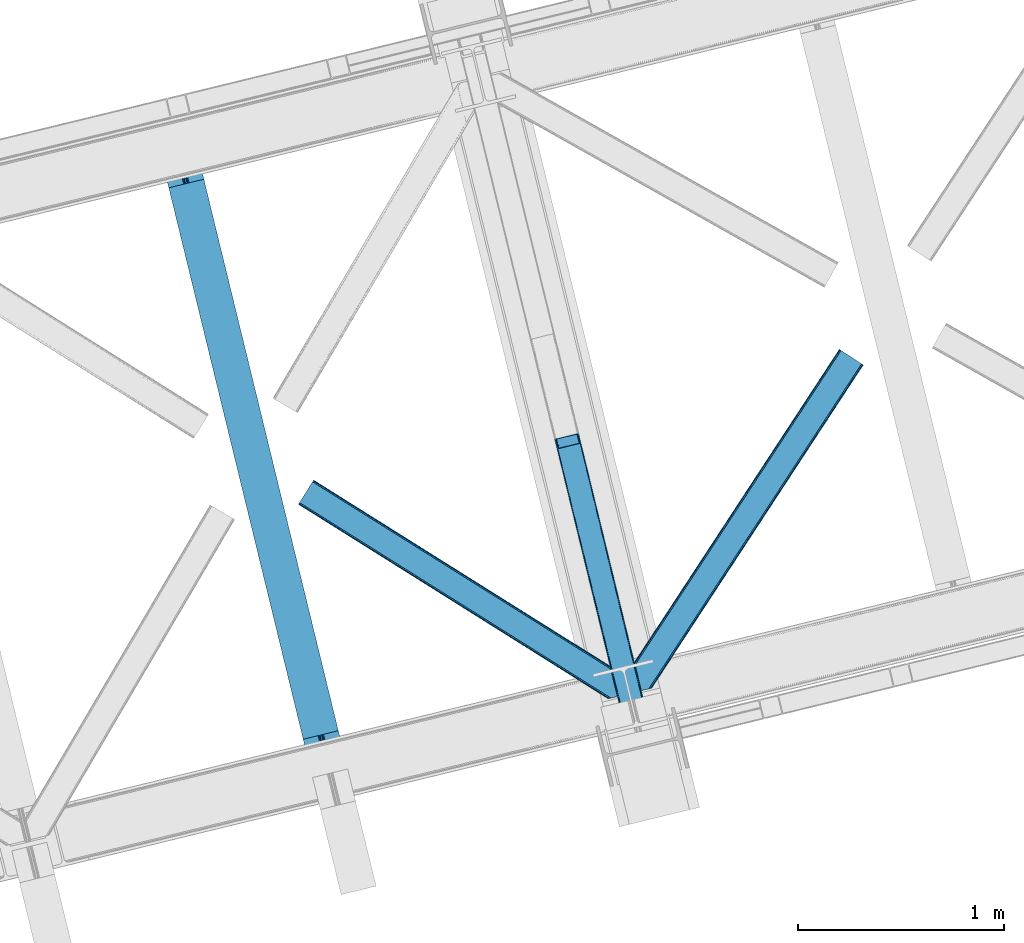
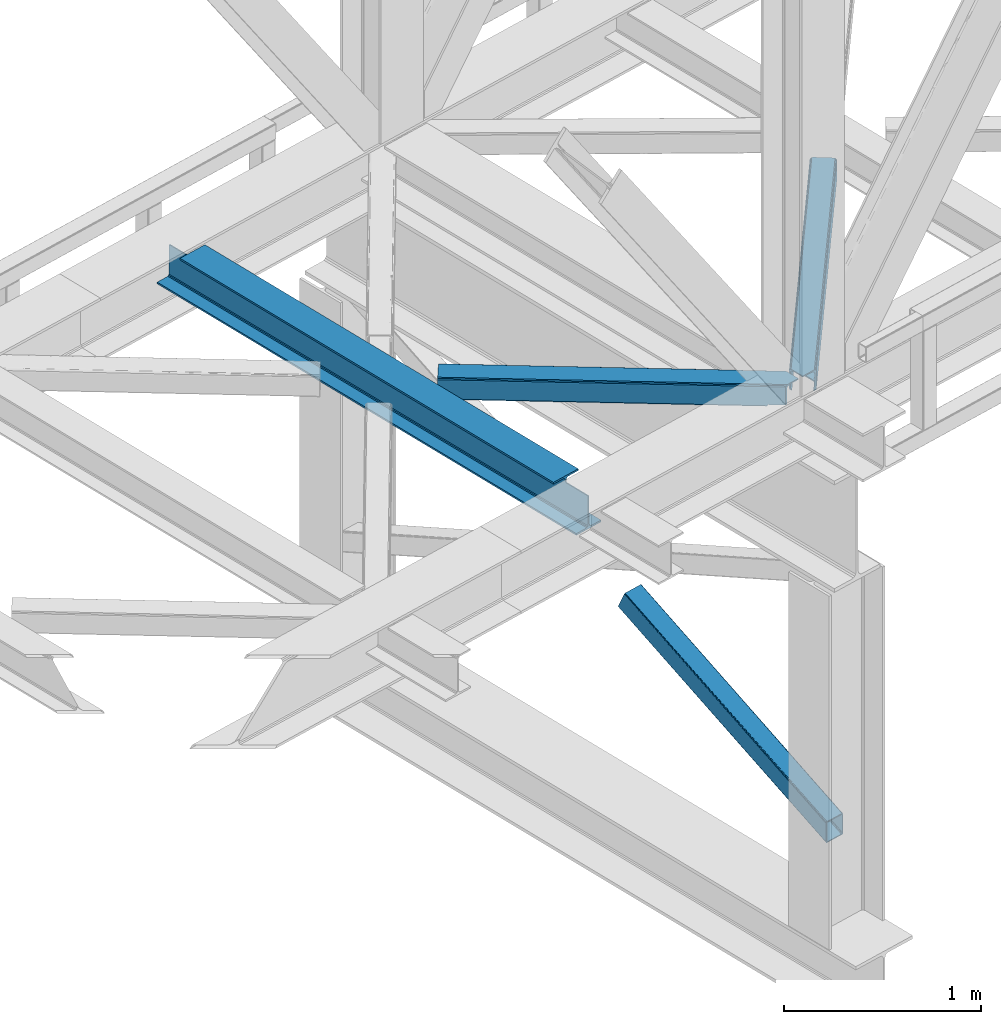
# One storey, part 36 of 93: 3 members, 1 beam.
"""IFC4 building model written with IfcOpenShell, lengths in millimetres."""

from ifc_helpers import new_model, entity, si_unit, converted_unit, derived_unit, direction, frame, origin, place, context, subcontext, project, spatial, triangles, polygons, material, type_object, element, save


model = new_model("IFC4")

# Units and contexts
model_context = context("Model", 3, precision=0.01, world=origin(), true_north=direction((6.12303176911189e-17, 1.0)))
plan_context = context("Plan", 3, precision=0.01, world=origin(), true_north=direction((6.12303176911189e-17, 1.0)))
body_context = subcontext(model_context, "Body", "Model", "MODEL_VIEW")
ifc_project = project(units=[si_unit("LENGTHUNIT", "METRE", prefix="MILLI"), si_unit("AREAUNIT", "SQUARE_METRE"), si_unit("VOLUMEUNIT", "CUBIC_METRE"), converted_unit("PLANEANGLEUNIT", "DEGREE", entity("IfcRatioMeasure", 0.0174532925199433), si_unit("PLANEANGLEUNIT", "RADIAN"), dimensions=[0, 0, 0, 0, 0, 0, 0]), si_unit("MASSUNIT", "GRAM", prefix="KILO"), derived_unit("MASSDENSITYUNIT", [(si_unit("MASSUNIT", "GRAM", prefix="KILO"), 1), (si_unit("LENGTHUNIT", "METRE"), -3)]), derived_unit("MOMENTOFINERTIAUNIT", [(si_unit("LENGTHUNIT", "METRE"), 4)]), si_unit("TIMEUNIT", "SECOND"), si_unit("FREQUENCYUNIT", "HERTZ"), si_unit("THERMODYNAMICTEMPERATUREUNIT", "DEGREE_CELSIUS"), derived_unit("THERMALTRANSMITTANCEUNIT", [(si_unit("MASSUNIT", "GRAM", prefix="KILO"), 1), (si_unit("THERMODYNAMICTEMPERATUREUNIT", "KELVIN"), -1), (si_unit("TIMEUNIT", "SECOND"), -3)]), derived_unit("VOLUMETRICFLOWRATEUNIT", [(si_unit("LENGTHUNIT", "METRE"), 3), (si_unit("TIMEUNIT", "SECOND"), -1)]), derived_unit("MASSFLOWRATEUNIT", [(si_unit("MASSUNIT", "GRAM", prefix="KILO"), 1), (si_unit("TIMEUNIT", "SECOND"), -1)]), derived_unit("ROTATIONALFREQUENCYUNIT", [(si_unit("TIMEUNIT", "SECOND"), -1)]), si_unit("ELECTRICCURRENTUNIT", "AMPERE"), si_unit("ELECTRICVOLTAGEUNIT", "VOLT"), si_unit("POWERUNIT", "WATT"), si_unit("FORCEUNIT", "NEWTON", prefix="KILO"), si_unit("ILLUMINANCEUNIT", "LUX"), si_unit("LUMINOUSFLUXUNIT", "LUMEN"), si_unit("LUMINOUSINTENSITYUNIT", "CANDELA"), derived_unit("USERDEFINED", [(si_unit("MASSUNIT", "GRAM", prefix="KILO"), -1), (si_unit("LENGTHUNIT", "METRE"), -2), (si_unit("TIMEUNIT", "SECOND"), 3), (si_unit("LUMINOUSFLUXUNIT", "LUMEN"), 1)]), derived_unit("LINEARVELOCITYUNIT", [(si_unit("LENGTHUNIT", "METRE"), 1), (si_unit("TIMEUNIT", "SECOND"), -1)]), si_unit("PRESSUREUNIT", "PASCAL"), derived_unit("USERDEFINED", [(si_unit("LENGTHUNIT", "METRE"), -2), (si_unit("MASSUNIT", "GRAM", prefix="KILO"), 1), (si_unit("TIMEUNIT", "SECOND"), -2)]), derived_unit("LINEARFORCEUNIT", [(si_unit("MASSUNIT", "GRAM", prefix="KILO"), 1), (si_unit("LENGTHUNIT", "METRE"), 1), (si_unit("TIMEUNIT", "SECOND"), -2), (si_unit("LENGTHUNIT", "METRE"), -1)]), derived_unit("PLANARFORCEUNIT", [(si_unit("MASSUNIT", "GRAM", prefix="KILO"), 1), (si_unit("LENGTHUNIT", "METRE"), 1), (si_unit("TIMEUNIT", "SECOND"), -2), (si_unit("LENGTHUNIT", "METRE"), -2)])], contexts=[model_context, plan_context])

# Site, building, storey
site_placement = place(None, origin())
site = spatial("IfcSite", under=ifc_project, at=site_placement, CompositionType="ELEMENT")
building_placement = place(site_placement, origin())
building = spatial("IfcBuilding", under=site, at=building_placement, CompositionType="ELEMENT")
storey_placement = place(building_placement, frame((0.0, 0.0, 15900.0)))
storey = spatial("IfcBuildingStorey", under=building, at=storey_placement, CompositionType="ELEMENT", Elevation=15900.0)

# Beam
ifc_material = material(Name="Metal painted (White)")
beam_type = type_object("IfcBeamType", PredefinedType="BEAM")
beam_placement = place(storey_placement, frame((-50891.9203165224, 5381.26080085439, 3441.0)))
element("IfcBeam", 1, at=beam_placement, inside=storey, type_object=beam_type, material=ifc_material, ObjectType="Steel Beam", PredefinedType="BEAM", context=body_context, shape_type="Tessellation", body=[
    polygons([(900.98534618944, 41.4445662733081, 11.000000000004), (900.98534618944, 41.4445662733081, 2.16573425859679e-12), (170.021610174761, 3040.13999372697, 2.16573425859679e-12), (170.021610174761, 3040.13999372697, 11.000000000004), (834.919806235823, 25.3403919499656, 11.000000000004), (103.956070221144, 3024.03581940362, 11.000000000004), (828.971056214531, 23.8903211957385, 12.2179274798217), (98.0073201998513, 3022.5857486494, 12.2179274798217), (823.927949458422, 22.6610105689183, 15.6862915010192), (92.9642134437427, 3021.35643802258, 15.6862915010192), (820.558253255246, 21.8396114687119, 20.8770650821657), (89.5945172405668, 3020.53503892237, 20.8770650821657), (819.374973305552, 21.5511744621195, 27.0000000000047), (88.4112372908809, 3020.24660191578, 27.0000000000047), (81.6103728838888, 3018.58881926485, 27.0000000000047), (81.6103728838888, 3018.58881926485, 203.000000000006), (88.4112372908723, 3020.24660191578, 203.000000000006), (0.0, 2998.69542745366, 2.16573425859679e-12), (0.0, 2998.69542745366, 10.9999999999997), (66.0655399536172, 3014.799601777, 11.000000000004), (72.0142899749184, 3016.24967253123, 12.2179274798217), (77.057396731027, 3017.47898315805, 15.6862915010192), (80.4270929342029, 3018.30038225826, 20.8770650821657), (819.374973305552, 21.5511744621195, 203.000000000006), (812.574108898559, 19.8933918111876, 203.000000000006), (812.574108898559, 19.8933918111876, 27.0000000000047), (811.390828948873, 19.6049548045963, 20.8770650821657), (808.021132745689, 18.7835557043887, 15.6862915010192), (802.978025989589, 17.5542450775675, 12.2179274798217), (797.029275968288, 16.1041743233425, 11.000000000004), (730.963736014679, -1.08286712929839e-12, 10.9999999999997), (730.963736014679, -1.08286712929839e-12, 2.16573425859679e-12), (779.675212882749, 184.415062601691, 203.069791966819), (128.020401343512, 2857.75452019162, 203.000000000006), (128.243282132658, 2856.8401777572, 203.617301946336), (128.256196377177, 2856.7871977843, 217.000003693143), (779.530009633833, 185.010597404071, 217.000003676718), (779.530880241722, 185.007025963191, 204.00000679514), (772.96491171832, 182.385463974441, 203.006342981529), (772.742064056782, 183.299815969774, 203.617301946336), (772.729149812254, 183.352795942668, 217.000003693143), (121.455336555608, 2855.1293963229, 217.000003676718), (121.45446594771, 2855.13296776377, 204.00000679514), (121.310166358664, 2855.72494066435, 203.076120467494), (121.219536936511, 2856.09673754069, 203.000000000006), (780.713494357877, 185.298194377514, 223.122939328039), (784.082490766539, 186.122464201393, 228.313710402595), (789.125126170563, 187.353708426698, 231.782072735464), (795.073705041275, 188.80448128138, 232.999999602236), (861.13915590679, 204.909021065314, 232.999999283132), (861.137682570352, 204.915065042187, 243.999994005812), (691.116301666431, 163.469558245297, 243.999994827032), (691.117775002877, 163.463514268424, 233.000000104353), (757.183225868392, 179.568054052358, 232.999999785253), (763.132130996731, 181.017488520583, 231.782072861012), (768.175695503853, 182.244921343717, 228.313710479427), (771.546082413602, 183.063487001147, 223.12293937232), (120.271851831563, 2854.84179934945, 223.122939328039), (116.902855422893, 2854.01752952557, 228.313710402595), (111.860220018877, 2852.78628530027, 231.782072735464), (105.911641148165, 2851.33551244559, 232.999999602236), (39.8461902826419, 2835.23097266165, 232.999999283128), (39.8476636190794, 2835.22492868478, 243.999994005812), (209.869044522992, 2876.67043548167, 243.999994827032), (209.867571186554, 2876.67647945854, 233.000000104357), (143.802120321031, 2860.57193967461, 232.999999785253), (137.85321519271, 2859.12250520638, 231.782072861012), (132.809650685579, 2857.89507238325, 228.313710479427), (129.439263775838, 2857.07650672582, 223.12293937232)], [[[1, 2, 3, 4]], [[5, 1, 4, 6]], [[7, 5, 6, 8]], [[9, 7, 8, 10]], [[11, 9, 10, 12]], [[13, 11, 12, 14]], [[15, 16, 17, 14, 12, 10, 8, 6, 4, 3, 18, 19, 20, 21, 22, 23]], [[13, 24, 25, 26, 27, 28, 29, 30, 31, 32, 2, 1, 5, 7, 9, 11]], [[2, 32, 18, 3]], [[32, 31, 19, 18]], [[31, 30, 20, 19]], [[27, 26, 15, 23]], [[28, 27, 23, 22]], [[29, 28, 22, 21]], [[30, 29, 21, 20]], [[33, 24, 13, 14, 17, 34, 35, 36, 37, 38]], [[25, 39, 40, 41, 42, 43, 44, 16, 15, 26]], [[39, 25, 24, 33]], [[45, 34, 17, 16]], [[41, 40, 38, 37, 46, 47, 48, 49, 50, 51, 52, 53, 54, 55, 56, 57]], [[42, 58, 59, 60, 61, 62, 63, 64, 65, 66, 67, 68, 69, 36, 35, 43]], [[46, 37, 36, 69]], [[47, 46, 69, 68]], [[48, 47, 68, 67]], [[49, 48, 67, 66]], [[50, 49, 66, 65]], [[51, 50, 65, 64]], [[52, 51, 64, 63]], [[53, 52, 63, 62]], [[54, 53, 62, 61]], [[55, 54, 61, 60]], [[56, 55, 60, 59]], [[57, 56, 59, 58]], [[41, 57, 58, 42]]], closed=False),
])

# Members
member_type_1 = type_object("IfcMemberType", PredefinedType="BRACE")
member_1_placement = place(storey_placement, frame((-48982.3357543945, 5508.86839599609, 911.279672241211)))
element("IfcMember", 2, at=member_1_placement, inside=storey, type_object=member_type_1, ObjectType="Steel Vertical Brace", PredefinedType="BRACE", context=body_context, shape_type="Tessellation", body=[
    triangles([(109.104968261716, 1516.67777252197, 692.224026489257), (472.287451171876, 26.761738586426, 0.0), (369.303039550781, 1.65803833007885, 0.0), (6.11590576171875, 1491.57407226563, 692.224026489257), (115.806884765625, 1516.48185424805, 696.163320922849), (116.583581542967, 1515.53714447022, 698.605032348631), (479.087036132813, 28.4191955566412, 7.68092651366896), (114.109313964844, 1517.03065795899, 694.092517089841), (478.091748046871, 28.1761871337894, 4.96481323242188), (111.755969238278, 1517.09925842285, 692.710043334959), (477.096459960936, 27.9337600708013, 2.24986267089844), (474.691955566406, 27.3477493286136, 1.12551269531104), (126.913183593751, 1473.16763763428, 795.217739868163), (479.087036132813, 28.4191955566412, 123.979641723632), (123.345959472652, 1469.55971832275, 801.112728881835), (120.797277832033, 1468.71209564209, 801.59758300781), (472.287451171876, 26.761738586426, 131.659405517577), (125.406298828122, 1470.70383453369, 799.729092407226), (474.691955566406, 27.3477493286136, 130.53505554199), (126.657385253908, 1471.97061767578, 797.659451293945), (477.096459960936, 27.9337600708013, 129.409542846679), (478.091748046871, 28.1761871337894, 126.694592285156), (369.303039550781, 1.65803833007885, 131.659405517577), (17.8082153320283, 1443.60839538574, 801.59758300781), (10.3296020507769, 1444.74844207764, 795.217739868163), (362.498803710936, 0.0, 123.979641723632), (363.494091796871, 0.243008422851744, 126.694592285156), (11.1062988281265, 1443.80431365967, 797.659451293945), (364.494030761714, 0.486016845703489, 129.409542846679), (12.7992187499985, 1443.25550994873, 799.729092407226), (366.898535156251, 1.07202758789117, 130.53505554199), (15.1572143554658, 1443.18690948486, 801.112728881835), (0.0, 1487.11853027344, 698.605032348631), (362.498803710936, 0.0, 7.68092651366896), (366.898535156251, 1.07202758789117, 1.12551269531104), (3.56722412109229, 1490.72644958496, 692.710043334959), (364.494030761714, 0.486016845703489, 2.24986267089844), (1.50688476562209, 1489.58233337402, 694.092517089841), (363.494091796871, 0.243008422851744, 4.96481323242188), (0.25579833984375, 1488.31496887207, 696.163320922849), (112.216406250001, 1512.35478057861, 703.161730957028), (111.43505859375, 1513.29949035645, 700.720019531247), (109.742138671871, 1513.84771270752, 698.650378417966), (104.733142089841, 1513.49482727051, 696.781887817382), (107.384143066403, 1513.91631317139, 697.266741943356), (120.057788085935, 1471.51831970215, 795.172393798828), (121.569323730466, 1473.98212280273, 790.661041259766), (121.313525390622, 1472.7856842041, 793.102752685547), (118.002099609374, 1470.37362213135, 796.55486755371), (115.448767089845, 1469.52599945068, 797.040884399412), (6.85539550780959, 1488.76784820557, 698.650378417966), (5.59965820312209, 1487.50048370361, 700.720019531247), (11.4644165039063, 1490.75958709717, 696.781887817382), (8.91108398437063, 1489.91254577637, 697.266741943356), (5.34385986327834, 1486.30404510498, 703.161730957028), (17.1710449218735, 1446.4384552002, 795.172393798828), (19.5290405273408, 1446.36985473633, 796.55486755371), (15.4781250000015, 1446.98667755127, 793.102752685547), (22.1800415039033, 1446.79075927734, 797.040884399412), (14.69677734375, 1447.9313873291, 790.661041259766), (371.754052734374, 2.2562576293949, 125.048181152342), (374.158557128903, 2.84226837158258, 126.173693847653), (369.349548339844, 1.66966552734448, 123.923831176755), (367.358972167967, 1.18423004150463, 118.492767333984), (368.354260253902, 1.42723846435547, 121.208880615231), (472.236291503905, 26.7495300292976, 123.923831176755), (467.427282714845, 25.5775085449222, 126.173693847653), (469.831787109375, 26.1635192871099, 125.048181152342), (473.231579589839, 26.9925384521484, 121.208880615231), (474.226867675781, 27.2349655151374, 118.492767333984), (369.349548339844, 1.66966552734448, 7.73557434081886), (371.754052734374, 2.2562576293949, 6.61122436523146), (367.358972167967, 1.18423004150463, 13.166638183593), (368.354260253902, 1.42723846435547, 10.4505249023423), (374.158557128903, 2.84226837158258, 5.48571166992042), (472.236291503905, 26.7495300292976, 7.73557434081886), (473.231579589839, 26.9925384521484, 10.4505249023423), (469.831787109375, 26.1635192871099, 6.61122436523146), (474.226867675781, 27.2349655151374, 13.166638183593), (467.427282714845, 25.5775085449222, 5.48571166992042)], [[1, 2, 3], [3, 4, 1], [5, 6, 7], [8, 5, 9], [10, 8, 11], [1, 10, 12], [12, 2, 1], [11, 12, 10], [9, 11, 8], [7, 9, 5], [6, 13, 14], [14, 7, 6], [15, 16, 17], [18, 15, 19], [20, 18, 21], [13, 20, 22], [22, 14, 13], [21, 22, 20], [19, 21, 18], [17, 19, 15], [17, 16, 23], [24, 23, 16], [25, 26, 27], [28, 27, 29], [30, 29, 31], [32, 31, 23], [23, 24, 32], [31, 32, 30], [29, 30, 28], [27, 28, 25], [25, 33, 26], [34, 26, 33], [4, 3, 35], [36, 35, 37], [38, 37, 39], [40, 39, 34], [34, 33, 40], [39, 40, 38], [37, 38, 36], [35, 36, 4], [41, 6, 42], [43, 5, 8], [8, 10, 43], [6, 41, 13], [6, 5, 43], [43, 42, 6], [44, 1, 4], [1, 45, 43], [44, 45, 1], [1, 43, 10], [18, 46, 15], [47, 13, 41], [46, 20, 13], [48, 13, 47], [20, 46, 18], [46, 16, 15], [13, 48, 46], [46, 49, 16], [16, 50, 24], [50, 16, 49], [51, 33, 52], [4, 53, 44], [54, 4, 51], [4, 54, 53], [51, 4, 36], [55, 52, 33], [36, 38, 51], [40, 51, 38], [55, 33, 25], [40, 33, 51], [56, 32, 24], [57, 56, 24], [58, 25, 56], [59, 24, 50], [24, 59, 57], [30, 32, 56], [25, 60, 55], [28, 56, 25], [60, 25, 58], [56, 28, 30], [61, 62, 23], [27, 63, 31], [27, 31, 29], [23, 62, 17], [23, 31, 61], [63, 61, 31], [64, 26, 34], [26, 65, 63], [64, 65, 26], [26, 63, 27], [19, 66, 22], [67, 17, 62], [68, 19, 17], [68, 17, 67], [22, 21, 19], [66, 14, 22], [19, 68, 66], [66, 69, 14], [14, 70, 7], [70, 14, 69], [71, 35, 72], [34, 73, 64], [74, 34, 71], [34, 74, 73], [71, 34, 39], [72, 3, 75], [71, 39, 35], [35, 39, 37], [75, 3, 2], [35, 3, 72], [76, 9, 7], [77, 76, 7], [78, 12, 76], [79, 7, 70], [7, 79, 77], [12, 9, 76], [2, 80, 75], [12, 78, 2], [80, 2, 78], [11, 9, 12], [80, 44, 75], [53, 75, 44], [44, 80, 78], [45, 78, 76], [43, 76, 77], [42, 77, 79], [79, 41, 42], [77, 42, 43], [76, 43, 45], [78, 45, 44], [47, 41, 70], [79, 70, 41], [47, 70, 69], [48, 69, 66], [46, 66, 68], [49, 68, 67], [67, 50, 49], [68, 49, 46], [66, 46, 48], [69, 48, 47], [50, 67, 59], [62, 59, 67], [57, 59, 62], [56, 57, 61], [58, 56, 63], [60, 58, 65], [65, 64, 60], [63, 65, 58], [61, 63, 56], [62, 61, 57], [55, 60, 64], [64, 73, 55], [52, 55, 73], [51, 52, 74], [54, 51, 71], [53, 54, 72], [72, 75, 53], [71, 72, 54], [74, 71, 51], [73, 74, 52]]),
])
member_type_2 = type_object("IfcMemberType", PredefinedType="BRACE")
member_2_placement = place(storey_placement, frame((-48630.0642333984, 5769.51876525879, 3511.0000579834)))
element("IfcMember", 3, at=member_2_placement, inside=storey, type_object=member_type_2, ObjectType="Steel Horizontal Brace", PredefinedType="BRACE", context=body_context, shape_type="Tessellation", body=[
    triangles([(109.770043945311, 259.949830627442, 7.52047119140843), (115.030187988275, 238.365682983398, 7.77510681152489), (114.216284179682, 239.94640045166, 8.3320495605476), (108.807312011719, 259.662057495118, 8.52041015625218), (113.6349243164, 239.859777832031, 8.52041015625218), (112.207104492183, 237.677352905273, 8.52041015625218), (91.0363037109346, 232.516621398926, 8.52041015625218), (109.532849121089, 237.025648498535, 9.50058288574292), (90.2596069335923, 232.32767944336, 9.50058288574292), (5.01829833984084, 77.405158996582, 9.50058288574292), (0.62786865234375, 95.4308029174808, 9.50058288574292), (1046.62448730468, 1651.75324859619, 6.99957275390625), (1041.02017822265, 1655.42221069336, 8.3320495605476), (116.699853515624, 231.514356994629, 6.99957275390625), (1036.27163085937, 1658.53190460205, 12.1260040283232), (3.92999267578125, 81.8752349853512, 12.1260040283232), (1033.0950805664, 1660.61026611328, 17.8035644531265), (2.70216064452688, 86.9220199584961, 17.8035644531265), (1031.98352050781, 1661.3398727417, 24.4996673583992), (2.26962890624418, 88.6940048217775, 24.4996673583992), (1122.75472412109, 1601.90454711914, 6.99957275390625), (146.20968017578, 110.458955383301, 6.99957275390625), (1031.98352050781, 1661.3398727417, 115.501089477541), (2.26962890624418, 88.6940048217775, 115.501089477541), (1033.0950805664, 1660.61026611328, 122.196029663086), (2.70216064452688, 86.9220199584961, 122.196029663086), (1036.27163085937, 1658.53190460205, 127.87475280762), (3.92999267578125, 81.8752349853512, 127.87475280762), (1041.02017822265, 1655.42221069336, 131.667544555665), (5.77174072265188, 74.322789001465, 131.667544555665), (1046.62448730468, 1651.75324859619, 133.000021362306), (7.94370117186918, 65.4140304565426, 133.000021362306), (1027.23962402344, 1664.44433441162, 10.8028289794929), (0.520898437498545, 95.8714736938473, 10.8691040039084), (0.0, 98.0056457519531, 17.5000946044929), (1035.16472167968, 1659.2562789917, 1.33247680664135), (112.258264160155, 249.73533782959, 1.33247680664135), (110.542089843744, 256.771536254882, 5.59500732422021), (109.077062988275, 259.839372253418, 8.31925964355469), (1030.4161743164, 1662.36655426025, 5.12526855468968), (1040.76903076172, 1655.58789825439, 0.0), (114.430224609372, 240.826579284668, 0.0), (1026.12806396484, 1665.1745223999, 17.5000946044929), (1128.61018066406, 1598.06989746094, 0.0), (148.479309082031, 101.147314453125, 0.0), (150.651269531249, 92.2385559082031, 1.33247680664135), (148.507214355464, 101.029298400879, 8.50064392089917), (152.488366699217, 84.686109924316, 5.12526855468968), (153.344128417964, 81.1822540283201, 8.50064392089917), (1026.12806396484, 1665.1745223999, 122.500662231447), (0.0, 98.0056457519531, 122.500662231447), (1040.76903076172, 1655.58789825439, 139.999594116212), (1035.16472167968, 1659.2562789917, 138.667117309571), (3.50211181640043, 83.6350112915043, 138.667117309571), (5.674072265625, 74.7262527465818, 139.999594116212), (1030.4161743164, 1662.36655426025, 134.874325561526), (1.66036376952979, 91.1874572753904, 134.874325561526), (1027.23962402344, 1664.44433441162, 129.197927856447), (0.432531738275429, 96.2336608886717, 129.197927856447), (23.8869140624956, 0.0, 139.999594116212), (23.8869140624956, 0.0, 133.000021362306), (1128.61018066406, 1598.06989746094, 139.999594116212), (93.3338378906192, 16.9280364990236, 139.999594116212), (1122.75472412109, 1601.90454711914, 133.000021362306), (83.3763061523423, 14.5008590698244, 133.000021362306), (1143.25114746093, 1588.48385467529, 122.500662231447), (1142.13958740234, 1589.21346130371, 129.197927856447), (118.225341796875, 22.9951080322262, 122.500662231447), (116.327783203124, 22.5335083007813, 129.197927856447), (1138.96303710937, 1591.29182281494, 134.874325561526), (110.932763671874, 21.2184722900392, 134.874325561526), (1134.21448974609, 1594.4020980835, 138.667117309571), (102.858837890621, 19.2499877929686, 138.667117309571), (1143.25114746093, 1588.48385467529, 17.5000946044929), (118.225341796875, 22.9951080322262, 17.5000946044929), (1142.13958740234, 1589.21346130371, 10.8028289794929), (1133.1075805664, 1595.12647247314, 12.1260040283232), (1136.27947998047, 1593.04811096191, 17.8035644531265), (1137.39569091797, 1592.3185043335, 24.4996673583992), (1138.96303710937, 1591.29182281494, 5.12526855468968), (1134.21448974609, 1594.4020980835, 1.33247680664135), (1128.35903320312, 1598.23616638184, 8.3320495605476), (1133.1075805664, 1595.12647247314, 127.87475280762), (1137.39569091797, 1592.3185043335, 115.501089477541), (1136.27947998047, 1593.04811096191, 122.196029663086), (1128.35903320312, 1598.23616638184, 131.667544555665), (92.9013061523438, 16.8228103637693, 131.667544555665), (100.979882812499, 18.79129486084, 127.87475280762), (106.374902343749, 20.106330871582, 122.196029663086), (108.267810058591, 20.5685119628906, 115.501089477541), (108.267810058591, 20.5685119628906, 24.4996673583992), (100.979882812499, 18.79129486084, 12.1260040283232), (115.472021484369, 22.32421875, 9.50058288574292), (106.374902343749, 20.106330871582, 17.8035644531265), (96.1987792968721, 17.6262496948239, 9.50058288574292), (115.941760253903, 22.4393280029299, 10.8702667236357), (153.060424804688, 80.2392883300781, 9.00061340332104), (152.776721191403, 79.2969039916989, 9.50058288574292), (148.711853027344, 99.8677413940432, 8.8831787109375), (148.600231933589, 99.023606872559, 9.08781738281323), (148.493261718744, 98.1672637939455, 9.29478149414354), (148.381640624997, 97.3225479125977, 9.50058288574292)], [[1, 2, 3], [4, 5, 6], [6, 7, 4], [7, 6, 8], [8, 9, 7], [9, 8, 10], [10, 11, 9], [12, 13, 3], [3, 2, 12], [2, 14, 12], [15, 16, 8], [8, 13, 15], [8, 5, 13], [16, 10, 8], [8, 6, 5], [15, 17, 18], [18, 16, 15], [17, 19, 20], [20, 18, 17], [21, 12, 14], [14, 22, 21], [19, 23, 20], [24, 20, 23], [23, 25, 24], [26, 24, 25], [25, 27, 26], [28, 26, 27], [27, 29, 28], [30, 28, 29], [29, 31, 30], [32, 30, 31], [33, 34, 35], [36, 37, 38], [33, 4, 9], [33, 1, 39], [9, 34, 33], [9, 11, 34], [4, 7, 9], [40, 38, 1], [1, 33, 40], [38, 40, 36], [36, 41, 37], [42, 37, 41], [35, 43, 33], [41, 44, 42], [45, 42, 44], [14, 42, 22], [37, 2, 38], [2, 37, 42], [38, 2, 1], [42, 14, 2], [22, 42, 45], [46, 47, 45], [47, 46, 48], [45, 47, 22], [48, 49, 47], [50, 43, 35], [35, 51, 50], [52, 53, 54], [54, 55, 52], [53, 56, 57], [57, 54, 53], [56, 58, 59], [59, 57, 56], [58, 50, 51], [51, 59, 58], [28, 57, 26], [30, 32, 55], [32, 60, 55], [32, 61, 60], [54, 30, 55], [28, 54, 57], [16, 11, 10], [28, 30, 54], [51, 35, 20], [24, 26, 51], [24, 51, 20], [57, 59, 26], [26, 59, 51], [35, 18, 20], [18, 11, 16], [11, 18, 34], [35, 34, 18], [62, 55, 63], [62, 52, 55], [55, 60, 63], [64, 32, 31], [32, 64, 65], [61, 32, 65], [66, 67, 68], [69, 68, 67], [67, 70, 69], [71, 69, 70], [70, 72, 71], [73, 71, 72], [72, 62, 73], [63, 73, 62], [74, 66, 68], [68, 75, 74], [76, 77, 78], [79, 66, 74], [76, 78, 74], [76, 80, 77], [78, 79, 74], [77, 80, 81], [21, 44, 41], [44, 82, 81], [82, 44, 21], [82, 77, 81], [67, 83, 70], [84, 66, 79], [66, 85, 67], [85, 66, 84], [67, 85, 83], [62, 64, 52], [72, 70, 83], [83, 86, 72], [86, 64, 62], [62, 72, 86], [15, 36, 40], [41, 12, 21], [41, 13, 12], [13, 41, 36], [15, 13, 36], [19, 43, 50], [33, 17, 15], [40, 33, 15], [17, 33, 43], [19, 17, 43], [53, 27, 56], [52, 64, 31], [31, 29, 52], [29, 27, 53], [53, 52, 29], [58, 56, 27], [50, 23, 19], [25, 50, 58], [50, 25, 23], [25, 58, 27], [64, 86, 87], [87, 65, 64], [86, 83, 88], [88, 87, 86], [83, 85, 89], [89, 88, 83], [85, 84, 90], [90, 89, 85], [84, 79, 91], [91, 90, 84], [89, 68, 69], [87, 73, 63], [60, 65, 63], [65, 60, 61], [65, 87, 63], [88, 73, 87], [88, 89, 71], [71, 73, 88], [69, 71, 89], [91, 75, 68], [92, 93, 94], [89, 90, 68], [92, 95, 93], [91, 94, 75], [90, 91, 68], [96, 75, 94], [94, 93, 96], [76, 74, 75], [49, 80, 97], [98, 97, 80], [49, 48, 80], [76, 96, 98], [98, 80, 76], [96, 93, 98], [44, 81, 45], [46, 45, 81], [81, 80, 46], [48, 46, 80], [75, 96, 76], [82, 21, 22], [77, 82, 47], [47, 99, 77], [77, 100, 101], [100, 77, 99], [101, 102, 77], [77, 102, 92], [95, 92, 102], [22, 47, 82], [79, 78, 91], [94, 91, 78], [78, 77, 94], [92, 94, 77], [102, 101, 98], [101, 100, 97], [100, 99, 49], [99, 47, 49], [102, 98, 93], [93, 95, 102]]),
])
member_type_3 = type_object("IfcMemberType", PredefinedType="BRACE")
member_3_placement = place(storey_placement, frame((-50224.5436523438, 5740.77633361816, 3511.0000579834)))
element("IfcMember", 4, at=member_3_placement, inside=storey, type_object=member_type_3, ObjectType="Steel Horizontal Brace", PredefinedType="BRACE", context=body_context, shape_type="Tessellation", body=[
    triangles([(9.3017578125, 956.602075195313, 0.0), (65.121606445311, 1045.5350189209, 0.0), (1381.50172119141, 219.29300994873, 0.0), (1417.17861328125, 72.9298507690428, 0.0), (1422.67130126953, 50.3934356689451, 10.8028289794929), (1423.12708740235, 48.5365722656252, 17.5000946044929), (0.0, 941.779724121094, 17.5000946044929), (0.706933593748545, 942.908143615723, 10.8028289794929), (1421.3830078125, 55.6809036254881, 5.12526855468968), (2.72076416015625, 946.121319580078, 5.12526855468968), (1419.45289306641, 63.5949554443359, 1.33247680664135), (5.73918457031687, 950.929747009277, 1.33247680664135), (68.6795288085923, 1051.20734710693, 1.33247680664135), (71.6979492187529, 1056.016355896, 5.12526855468968), (1377.30662841797, 236.497192382813, 5.17061462402489), (73.7164306640625, 1059.22895050049, 10.8028289794929), (1382.10168457031, 238.005239868164, 10.8028289794929), (1383.90622558594, 238.445329284668, 17.5000946044929), (74.423364257811, 1060.35736999512, 17.5000946044929), (1379.22744140625, 228.627905273437, 1.33247680664135), (1377.23221435547, 236.818103027344, 17.5198608398459), (1383.90622558594, 238.445329284668, 18.5197998046897), (1378.19959716797, 237.054716491699, 18.5197998046897), (1379.50649414062, 231.698066711426, 18.5197998046897), (1563.91384277344, 125.462109375, 18.5197998046897), (1566.64855957031, 114.236050415039, 18.5197998046897), (1563.91384277344, 125.462109375, 122.500662231447), (74.423364257811, 1060.35736999512, 122.500662231447), (1564.36497802735, 123.605245971679, 129.197927856447), (73.7164306640625, 1059.22895050049, 129.197927856447), (1565.65327148438, 118.317196655274, 134.874325561526), (71.6979492187529, 1056.016355896, 134.874325561526), (1567.58338623047, 110.403144836426, 138.667117309571), (68.6795288085923, 1051.20734710693, 138.667117309571), (1569.85766601563, 101.068249511719, 139.999594116212), (65.121606445311, 1045.5350189209, 139.999594116212), (67.9772460937529, 1050.08706665039, 12.1260040283232), (1379.67392578125, 226.784413146973, 12.1260040283232), (1378.42749023438, 231.905030822754, 17.5198608398459), (69.9957275390625, 1053.30024261475, 17.8035644531265), (1566.29044189453, 115.704565429687, 24.4996673583992), (70.702661132811, 1054.42866210938, 24.4996673583992), (1381.60404052735, 218.870361328125, 8.3320495605476), (64.9588256835923, 1045.27863922119, 8.3320495605476), (1383.8783203125, 209.535466003418, 6.99957275390625), (61.400903320311, 1039.60631103516, 6.99957275390625), (13.0224609375, 962.530783081054, 6.99957275390625), (1414.80201416016, 82.6873947143558, 6.99957275390625), (1419.00640869141, 65.4384475708011, 12.1260040283232), (1420.25284423828, 60.3178298950197, 17.5198608398459), (1417.07629394531, 73.3524993896481, 8.3320495605476), (1566.29044189453, 115.704565429687, 115.501089477541), (70.702661132811, 1054.42866210938, 115.501089477541), (1569.95998535156, 100.646182250976, 131.667544555665), (1572.23891601562, 91.3107055664059, 133.000021362306), (61.400903320311, 1039.60631103516, 133.000021362306), (64.9588256835923, 1045.27863922119, 131.667544555665), (1568.03452148438, 108.559652709961, 127.87475280762), (67.9772460937529, 1050.08706665039, 127.87475280762), (1566.74157714844, 113.847702026367, 122.196029663086), (69.9957275390625, 1053.30024261475, 122.196029663086), (1589.21927490235, 21.6376327514645, 133.000021362306), (1589.21927490235, 21.6376327514645, 139.999594116212), (9.3017578125, 956.602075195313, 139.999594116212), (1524.16278076172, 5.77929840087927, 139.999594116212), (1515.09356689453, 3.56780548095685, 138.667117309571), (5.73918457031687, 950.929747009277, 138.667117309571), (1507.4010131836, 1.69291992187482, 134.874325561526), (2.72076416015625, 946.121319580078, 134.874325561526), (1502.26179199219, 0.439508056640989, 129.197927856447), (0.706933593748545, 942.908143615723, 129.197927856447), (1500.45260009765, 0.0, 122.500662231447), (0.0, 941.779724121094, 122.500662231447), (1424.34096679687, 47.7738281250004, 18.5197998046897), (1500.45260009765, 0.0, 18.5197998046897), (1421.60625, 58.9993057250977, 18.5197998046897), (1511.36821289063, 2.65972137451172, 18.5197998046897), (3.720703125, 947.708432006836, 24.4996673583992), (1509.9403930664, 2.31148681640661, 24.4996673583992), (4.42763671874854, 948.836851501464, 17.8035644531265), (1420.92722167969, 59.6585678100582, 18.0198303222678), (6.44611816406541, 952.050027465821, 12.1260040283232), (9.45988769531687, 956.858454895019, 8.3320495605476), (6.44611816406541, 952.050027465821, 127.87475280762), (13.0224609375, 962.530783081054, 133.000021362306), (9.45988769531687, 956.858454895019, 131.667544555665), (3.720703125, 947.708432006836, 115.501089477541), (4.42763671874854, 948.836851501464, 122.196029663086), (1524.57670898438, 5.87929229736346, 131.667544555665), (1516.88415527344, 4.00440673828143, 127.87475280762), (1511.74493408203, 2.75157623291034, 122.196029663086), (1533.65057373047, 8.09136657714862, 133.000021362306), (1509.9403930664, 2.31148681640661, 115.501089477541)], [[1, 2, 3], [3, 4, 1], [5, 6, 7], [7, 8, 5], [9, 5, 8], [8, 10, 9], [11, 9, 10], [10, 12, 11], [4, 11, 12], [12, 1, 4], [13, 14, 15], [16, 17, 15], [15, 14, 16], [18, 17, 19], [16, 19, 17], [20, 3, 2], [2, 13, 20], [15, 20, 13], [18, 21, 17], [18, 22, 23], [17, 21, 15], [21, 18, 23], [24, 22, 25], [22, 24, 23], [25, 26, 24], [25, 22, 27], [19, 22, 18], [22, 28, 27], [19, 28, 22], [29, 27, 30], [28, 30, 27], [31, 29, 32], [30, 32, 29], [33, 31, 34], [32, 34, 31], [35, 33, 36], [34, 36, 33], [37, 38, 39], [39, 40, 37], [24, 41, 42], [24, 26, 41], [42, 40, 39], [43, 38, 44], [37, 44, 38], [45, 43, 46], [44, 46, 43], [46, 47, 45], [48, 45, 47], [3, 48, 4], [43, 20, 38], [39, 15, 21], [15, 39, 38], [38, 20, 15], [43, 3, 20], [3, 45, 48], [43, 45, 3], [9, 49, 50], [50, 5, 9], [6, 5, 50], [49, 11, 51], [51, 4, 48], [4, 51, 11], [49, 9, 11], [41, 52, 53], [53, 42, 41], [54, 55, 56], [56, 57, 54], [58, 54, 57], [57, 59, 58], [60, 58, 59], [59, 61, 60], [52, 60, 61], [61, 53, 52], [58, 31, 33], [58, 33, 54], [55, 54, 35], [60, 31, 58], [62, 55, 63], [35, 63, 55], [54, 33, 35], [29, 31, 60], [25, 27, 52], [41, 25, 52], [25, 41, 26], [29, 60, 27], [60, 52, 27], [64, 35, 36], [35, 64, 65], [63, 35, 65], [66, 65, 64], [64, 67, 66], [68, 66, 67], [67, 69, 68], [70, 68, 69], [69, 71, 70], [72, 70, 71], [71, 73, 72], [74, 72, 6], [74, 75, 72], [73, 6, 72], [73, 7, 6], [74, 76, 77], [77, 75, 74], [78, 79, 76], [76, 80, 78], [76, 81, 80], [79, 77, 76], [50, 82, 80], [50, 49, 82], [51, 48, 83], [47, 83, 48], [49, 51, 82], [83, 82, 51], [16, 37, 40], [42, 28, 19], [16, 40, 19], [16, 14, 37], [40, 42, 19], [37, 14, 13], [46, 2, 1], [2, 44, 13], [44, 2, 46], [44, 37, 13], [30, 59, 32], [53, 28, 42], [28, 61, 30], [61, 28, 53], [30, 61, 59], [36, 56, 64], [34, 32, 59], [59, 57, 34], [57, 56, 36], [36, 34, 57], [82, 12, 10], [1, 47, 46], [1, 83, 47], [83, 1, 12], [82, 83, 12], [78, 7, 73], [8, 80, 82], [10, 8, 82], [80, 8, 7], [78, 80, 7], [67, 84, 69], [64, 56, 85], [85, 86, 64], [86, 84, 67], [67, 64, 86], [71, 69, 84], [73, 87, 78], [88, 73, 71], [73, 88, 87], [88, 71, 84], [89, 65, 66], [90, 66, 68], [91, 68, 70], [92, 63, 65], [89, 66, 90], [62, 63, 92], [89, 92, 65], [91, 90, 68], [72, 93, 91], [93, 72, 75], [79, 75, 77], [75, 79, 93], [72, 91, 70], [85, 55, 92], [85, 56, 55], [55, 62, 92], [91, 93, 88], [87, 88, 93], [90, 91, 84], [88, 84, 91], [89, 90, 86], [84, 86, 90], [92, 89, 85], [86, 85, 89], [93, 79, 78], [78, 87, 93]]),
])

save(model, "model.ifc")
